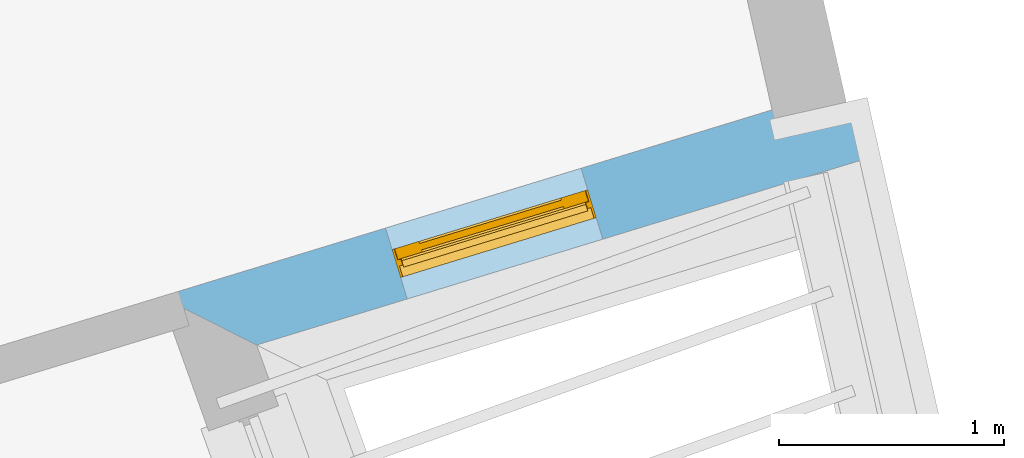
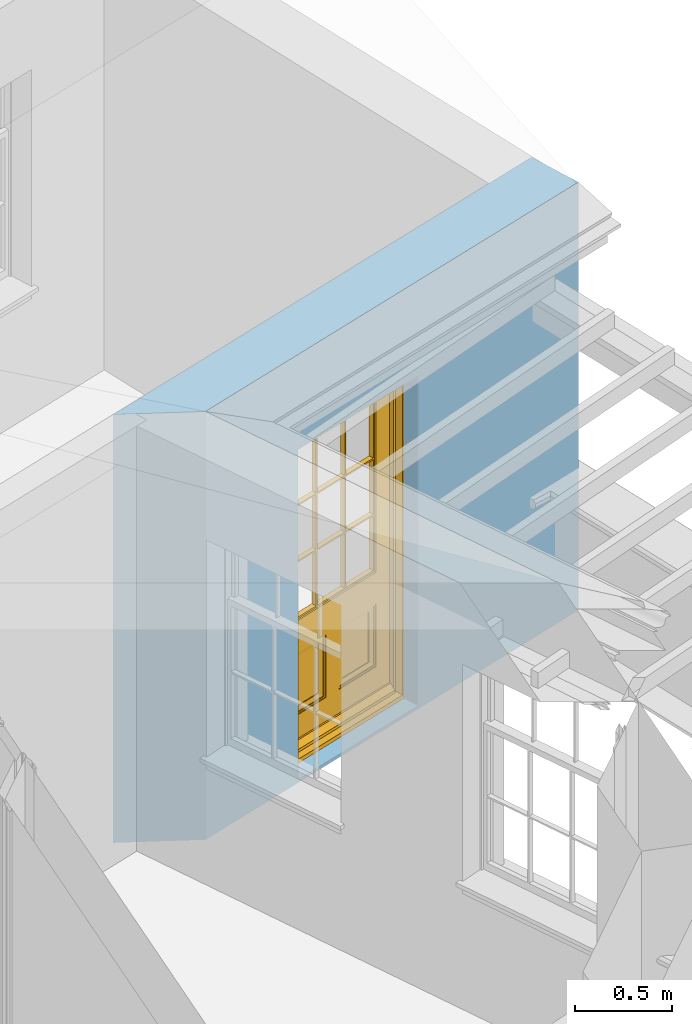
# One storey, part 7 of 10: 1 door, 1 opening, plus 1 element that does not belong to this part.
"""IFC2X3 building model written with IfcOpenShell, lengths in metres."""

from ifc_helpers import new_model, si_unit, frame, origin, place, context, subcontext, project, spatial, polyline, outline, extrude, faceted_brep, material, layer, layer_set, layer_usage, element, fill, save


model = new_model("IFC2X3")

# Units and contexts
model_context = context("Model", 3, world=origin())
body_context = subcontext(model_context, "Body", "Model", "MODEL_VIEW")
ifc_project = project(units=[si_unit("PLANEANGLEUNIT", "RADIAN"), si_unit("MASSUNIT", "GRAM", prefix="KILO"), si_unit("FORCEUNIT", "NEWTON", prefix="KILO"), si_unit("LENGTHUNIT", "METRE")], contexts=[model_context])

# Site, building, storey
site_placement = place(None, origin())
site = spatial("IfcSite", under=ifc_project, at=site_placement, CompositionType="ELEMENT")
building_placement = place(None, origin())
building = spatial("IfcBuilding", under=site, at=building_placement, Name="Building plot-9", CompositionType="ELEMENT")
storey_placement = place(None, frame((0.0, 0.0, 4.3)))
storey = spatial("IfcBuildingStorey", under=building, at=storey_placement, Name="Floor 1", CompositionType="ELEMENT", Elevation=4.3)

# Wall, opening, door
ifc_material = material(Name="Masonry")
ifc_layer = layer(ifc_material, 0.33, ventilated=False)
ifc_layer_set = layer_set([ifc_layer], Name="My Wall")
ifc_layer_usage = layer_usage(ifc_layer_set, "AXIS2", "NEGATIVE", 0.08)
wall_placement = place(storey_placement, origin())
wall = element("IfcWallStandardCase", 1, at=wall_placement, inside=storey, material=ifc_layer_usage, Name="exterior", context=body_context, shape_type="SweptSolid", body=[
    extrude(outline(polyline([(38.174894424001, 19.9322512434462), (38.6024618598675, 19.7178854834714), (41.3015513002929, 20.5430150145373), (41.2050755797842, 20.8585977063192), (38.174894424001, 19.9322512434462)])), origin(), (0.0, 0.0, 1.0), 2.7),
])
opening_placement = place(storey_placement, frame((0.0, 0.0, 0.0199999999999996)))
opening = element("IfcOpeningElement", 2, at=opening_placement, cuts=wall, Name="Opening", ObjectType="Opening", context=body_context, shape_type="SweptSolid", body=[
    extrude(outline(polyline([(39.2719325629492, 19.9225471145469), (40.1421757433175, 20.1885862226164), (40.0457000228088, 20.5041689143983), (39.1754568424405, 20.2381298063288), (39.2719325629492, 19.9225471145469)])), origin(), (0.0, 0.0, 1.0), 2.08),
])
door_placement = place(storey_placement, frame((39.1988448958971, 20.1616249113514, 0.0199999999999996), z_axis=(0.0, 0.0, 1.0), x_axis=(0.870243180368334, 0.266039108069496, 0.0)))
door = element("IfcDoor", 3, at=door_placement, inside=storey, Name="bedroom outside door", OverallHeight=2.08, OverallWidth=0.91, context=body_context, shape_type="Brep", held_by="IfcProductRepresentation", body=[
    faceted_brep([(0.545, -0.055, 0.265), (0.745, -0.055, 0.265), (0.745, -0.05, 0.265), (0.545, -0.05, 0.265), (0.745, -0.05, 0.58), (0.545, -0.05, 0.58), (0.545, -0.055, 0.58), (0.515, -0.06, 0.235), (0.775, -0.06, 0.235), (0.745, -0.055, 0.58), (0.515, -0.06, 0.61), (0.515, -0.065, 0.235), (0.775, -0.065, 0.235), (0.775, -0.06, 0.61), (0.515, -0.065, 0.61), (0.785, -0.065, 0.225), (0.505, -0.065, 0.225), (0.775, -0.065, 0.61), (0.505, -0.065, 0.62), (0.785, -0.065, 0.62), (0.505, -0.07, 0.225), (0.785, -0.07, 0.225), (0.505, -0.07, 0.62), (0.785, -0.07, 0.62), (0.883, -0.07, 0.075), (0.898, -0.07, 0.075), (0.405, -0.07, 0.62), (0.405, -0.07, 0.225), (0.027, -0.07, 0.075), (0.785, -0.07, 0.82), (0.125, -0.07, 0.82), (0.405, -0.065, 0.62), (0.405, -0.065, 0.225), (0.898, -0.07, 2.068), (0.027, -0.08, 0.075), (0.883, -0.08, 0.075), (0.125, -0.07, 0.225), (0.012, -0.07, 0.075), (0.785, -0.06, 0.82), (0.125, -0.06, 0.82), (0.125, -0.07, 0.62), (0.125, -0.065, 0.62), (0.395, -0.065, 0.61), (0.395, -0.065, 0.235), (0.125, -0.065, 0.225), (0.785, -0.07, 1.895), (0.027, -0.11, 0.045), (0.883, -0.11, 0.045), (0.558333, -0.06, 0.83), (0.351667, -0.06, 0.83), (0.125, -0.07, 1.895), (0.125, -0.06, 1.895), (0.785, -0.06, 1.895), (0.012, -0.07, 2.068), (0.135, -0.065, 0.61), (0.395, -0.06, 0.61), (0.395, -0.06, 0.235), (0.135, -0.065, 0.235), (0.027, -0.11, 0.027), (0.883, -0.11, 0.027), (0.568333, -0.06, 0.83), (0.558333, -0.03, 0.83), (0.351667, -0.03, 0.83), (0.341667, -0.06, 0.83), (0.135, -0.06, 1.185), (0.135, -0.06, 1.53), (0.775, -0.06, 1.53), (0.775, -0.06, 1.185), (0.135, -0.06, 0.61), (0.365, -0.055, 0.58), (0.365, -0.055, 0.265), (0.135, -0.06, 0.235), (0.568333, -0.06, 1.175), (0.558333, -0.06, 1.175), (0.775, -0.06, 0.83), (0.558333, -0.03, 1.175), (0.785, -0.03, 0.82), (0.125, -0.03, 0.82), (0.351667, -0.03, 1.175), (0.351667, -0.06, 1.175), (0.341667, -0.06, 1.175), (0.135, -0.06, 0.83), (0.135, -0.06, 1.175), (0.135, -0.03, 1.185), (0.135, -0.03, 1.53), (0.135, -0.06, 1.54), (0.351667, -0.06, 1.885), (0.558333, -0.06, 1.885), (0.775, -0.03, 1.53), (0.775, -0.03, 1.185), (0.775, -0.06, 1.175), (0.775, -0.06, 1.54), (0.165, -0.055, 0.58), (0.365, -0.05, 0.58), (0.365, -0.05, 0.265), (0.165, -0.055, 0.265), (0.568333, -0.03, 0.83), (0.568333, -0.03, 1.175), (0.568333, -0.06, 1.185), (0.558333, -0.06, 1.185), (0.775, -0.03, 0.83), (0.785, -0.02, 0.82), (0.125, -0.02, 0.82), (0.341667, -0.03, 0.83), (0.341667, -0.03, 1.175), (0.351667, -0.06, 1.185), (0.341667, -0.06, 1.185), (0.135, -0.03, 0.83), (0.341667, -0.03, 1.185), (0.125, -0.03, 1.895), (0.341667, -0.03, 1.53), (0.341667, -0.06, 1.53), (0.135, -0.06, 1.885), (0.341667, -0.06, 1.54), (0.341667, -0.06, 1.885), (0.558333, -0.03, 1.885), (0.351667, -0.03, 1.885), (0.568333, -0.06, 1.885), (0.785, -0.03, 1.895), (0.568333, -0.03, 1.185), (0.568333, -0.06, 1.53), (0.568333, -0.03, 1.53), (0.568333, -0.06, 1.54), (0.775, -0.06, 1.885), (0.165, -0.05, 0.58), (0.165, -0.05, 0.265), (0.775, -0.03, 1.175), (0.558333, -0.06, 1.53), (0.351667, -0.03, 1.185), (0.558333, -0.03, 1.185), (0.505, -0.02, 0.62), (0.405, -0.02, 0.62), (0.125, -0.02, 1.895), (0.785, -0.02, 1.895), (0.351667, -0.06, 1.53), (0.135, -0.03, 1.175), (0.135, -0.03, 1.54), (0.341667, -0.03, 1.54), (0.135, -0.03, 1.885), (0.351667, -0.06, 1.54), (0.558333, -0.03, 1.54), (0.558333, -0.06, 1.54), (0.351667, -0.03, 1.54), (0.775, -0.03, 1.54), (0.568333, -0.03, 1.54), (0.775, -0.03, 1.885), (0.558333, -0.03, 1.53), (0.405, -0.02, 0.225), (0.505, -0.02, 0.225), (0.125, -0.02, 0.62), (0.785, -0.02, 0.62), (0.012, -0.02, 2.068), (0.898, -0.02, 2.068), (0.351667, -0.03, 1.53), (0.341667, -0.03, 1.885), (0.568333, -0.03, 1.885), (0.405, -0.025, 0.225), (0.405, -0.025, 0.62), (0.505, -0.025, 0.62), (0.505, -0.025, 0.225), (0.898, -0.02, 0.027), (0.012, -0.02, 0.027), (0.125, -0.025, 0.62), (0.785, -0.025, 0.62), (0.395, -0.025, 0.235), (0.395, -0.025, 0.61), (0.125, -0.02, 0.225), (0.125, -0.025, 0.225), (0.515, -0.025, 0.61), (0.515, -0.025, 0.235), (0.785, -0.02, 0.225), (0.785, -0.025, 0.225), (0.135, -0.025, 0.61), (0.775, -0.025, 0.61), (0.135, -0.025, 0.235), (0.395, -0.03, 0.235), (0.395, -0.03, 0.61), (0.515, -0.03, 0.61), (0.515, -0.03, 0.235), (0.775, -0.025, 0.235), (0.135, -0.03, 0.61), (0.775, -0.03, 0.61), (0.135, -0.03, 0.235), (0.365, -0.035, 0.265), (0.365, -0.035, 0.58), (0.545, -0.035, 0.58), (0.545, -0.035, 0.265), (0.775, -0.03, 0.235), (0.165, -0.035, 0.58), (0.745, -0.035, 0.58), (0.165, -0.035, 0.265), (0.365, -0.04, 0.58), (0.365, -0.04, 0.265), (0.545, -0.04, 0.58), (0.545, -0.04, 0.265), (0.745, -0.035, 0.265), (0.165, -0.04, 0.58), (0.745, -0.04, 0.58), (0.165, -0.04, 0.265), (0.745, -0.04, 0.265), (0.885, -0.072, 0.025), (0.025, -0.072, 0.025), (0.025, -0.1, 0.025), (0.885, -0.1, 0.025), (0.9, -0.02, 0.025), (0.01, -0.02, 0.025), (0.9, -0.072, 0.025), (0.91, -0.02, 0.0), (0.0, -0.02, 0.0), (0.01, -0.072, 0.025), (0.9, -0.072, 2.07), (0.9, -0.02, 2.07), (0.885, -0.072, 2.055), (0.91, -0.02, 2.08), (0.01, -0.02, 2.07), (0.0, -0.02, 2.08), (0.01, -0.072, 2.07), (0.025, -0.072, 2.055), (0.0, -0.15, 2.08), (0.91, -0.15, 2.08), (0.01, -0.15, 2.07), (0.9, -0.15, 2.07), (0.01, -0.1, 2.07), (0.9, -0.1, 2.07), (0.0, -0.15, 0.0), (0.91, -0.15, 0.0), (0.01, -0.15, 0.025), (0.9, -0.15, 0.025), (0.01, -0.1, 0.025), (0.025, -0.1, 2.055), (0.9, -0.1, 0.025), (0.885, -0.1, 2.055), (0.898, -0.07, 0.027), (0.012, -0.07, 0.027), (0.883, -0.07, 0.027), (0.027, -0.07, 0.027)], [[[0, 1, 2, 3]], [[2, 4, 5, 3]], [[0, 3, 5, 6]], [[1, 0, 7, 8]], [[9, 4, 2, 1]], [[9, 6, 5, 4]], [[0, 6, 10, 7]], [[8, 7, 11, 12]], [[8, 13, 9, 1]], [[13, 10, 6, 9]], [[7, 10, 14, 11]], [[15, 12, 11, 16]], [[12, 17, 13, 8]], [[17, 14, 10, 13]], [[18, 16, 11, 14]], [[15, 19, 17, 12]], [[15, 16, 20, 21]], [[14, 17, 19, 18]], [[16, 18, 22, 20]], [[21, 23, 19, 15]], [[24, 25, 21, 20]], [[23, 22, 18, 19]], [[20, 22, 26, 27]], [[23, 21, 25]], [[28, 24, 20, 27]], [[22, 23, 29]], [[29, 30, 26, 22]], [[27, 26, 31, 32]], [[23, 25, 33, 29]], [[34, 35, 24, 28]], [[28, 27, 36, 37]], [[38, 39, 30, 29]], [[26, 30, 40]], [[26, 40, 41, 31]], [[42, 43, 32, 31]], [[32, 44, 36, 27]], [[33, 45, 29]], [[46, 47, 35, 34]], [[36, 40, 37]], [[39, 38, 48, 49]], [[50, 30, 39, 51]], [[29, 45, 52, 38]], [[53, 37, 40, 30]], [[44, 41, 40, 36]], [[31, 41, 54, 42]], [[43, 42, 55, 56]], [[57, 44, 32, 43]], [[50, 45, 33, 53]], [[47, 46, 58, 59]], [[60, 48, 38]], [[49, 48, 61, 62]], [[49, 63, 39]], [[50, 53, 30]], [[51, 39, 64, 65]], [[45, 50, 51, 52]], [[66, 67, 38, 52]], [[57, 54, 41, 44]], [[42, 54, 68, 55]], [[56, 55, 69, 70]], [[56, 71, 57, 43]], [[60, 72, 73, 48]], [[60, 38, 74]], [[48, 73, 75, 61]], [[76, 77, 62, 61]], [[62, 78, 79, 49]], [[49, 79, 80, 63]], [[63, 81, 39]], [[82, 64, 39]], [[65, 64, 83, 84]], [[85, 51, 65]], [[52, 51, 86, 87]], [[88, 89, 67, 66]], [[90, 38, 67]], [[91, 66, 52]], [[71, 68, 54, 57]], [[55, 68, 92, 69]], [[69, 93, 94, 70]], [[70, 95, 71, 56]], [[96, 97, 72, 60]], [[73, 72, 98, 99]], [[74, 38, 90]], [[100, 96, 60, 74]], [[75, 73, 79, 78]], [[61, 75, 97, 96]], [[101, 102, 77, 76]], [[77, 103, 62]], [[96, 76, 61]], [[103, 104, 78, 62]], [[80, 79, 105, 106]], [[63, 80, 104, 103]], [[81, 63, 103, 107]], [[81, 82, 39]], [[106, 64, 82, 80]], [[106, 108, 83, 64]], [[84, 83, 77, 109]], [[110, 111, 65, 84]], [[112, 51, 85]], [[113, 85, 65, 111]], [[114, 86, 51]], [[115, 87, 86, 116]], [[117, 52, 87]], [[118, 76, 89, 88]], [[119, 98, 67, 89]], [[120, 121, 88, 66]], [[67, 98, 72, 90]], [[91, 122, 120, 66]], [[91, 52, 123]], [[95, 92, 68, 71]], [[69, 92, 124, 93]], [[94, 93, 124, 125]], [[94, 125, 95, 70]], [[72, 97, 126, 90]], [[127, 99, 98, 120]], [[99, 105, 79, 73]], [[74, 90, 126, 100]], [[96, 100, 76]], [[128, 129, 75, 78]], [[97, 75, 129, 119]], [[130, 131, 102, 101]], [[109, 77, 102, 132]], [[133, 101, 76, 118]], [[77, 107, 103]], [[78, 104, 108, 128]], [[111, 106, 105, 134]], [[104, 80, 82, 135]], [[107, 135, 82, 81]], [[110, 108, 106, 111]], [[104, 135, 83, 108]], [[83, 135, 77]], [[136, 84, 109]], [[110, 84, 136, 137]], [[114, 51, 112]], [[85, 136, 138, 112]], [[113, 137, 136, 85]], [[111, 134, 139, 113]], [[86, 114, 113, 139]], [[140, 141, 87, 115]], [[139, 142, 116, 86]], [[109, 118, 115, 116]], [[117, 123, 52]], [[117, 87, 141, 122]], [[126, 89, 76]], [[143, 118, 88]], [[120, 98, 119, 121]], [[119, 89, 126, 97]], [[144, 143, 88, 121]], [[144, 122, 91, 143]], [[127, 120, 122, 141]], [[143, 91, 123, 145]], [[124, 92, 95, 125]], [[146, 129, 99, 127]], [[99, 129, 128, 105]], [[100, 126, 76]], [[121, 119, 129, 146]], [[147, 131, 130, 148]], [[131, 149, 102]], [[130, 101, 150]], [[102, 151, 132]], [[118, 109, 132, 133]], [[101, 133, 152]], [[107, 77, 135]], [[153, 128, 108, 110]], [[134, 105, 128, 153]], [[109, 138, 136]], [[153, 110, 137, 142]], [[154, 114, 112, 138]], [[137, 113, 114, 154]], [[141, 139, 134, 127]], [[141, 140, 142, 139]], [[144, 140, 115, 155]], [[142, 137, 154, 116]], [[155, 115, 118]], [[116, 154, 109]], [[117, 155, 145, 123]], [[122, 144, 155, 117]], [[143, 145, 118]], [[121, 146, 140, 144]], [[146, 127, 134, 153]], [[156, 157, 131, 147]], [[148, 130, 158, 159]], [[148, 160, 161, 147]], [[157, 162, 149, 131]], [[161, 151, 102, 149]], [[101, 152, 160, 150]], [[163, 158, 130, 150]], [[151, 152, 133, 132]], [[154, 138, 109]], [[142, 140, 146, 153]], [[145, 155, 118]], [[157, 156, 164, 165]], [[147, 166, 167, 156]], [[168, 169, 159, 158]], [[170, 148, 159, 171]], [[148, 170, 160]], [[166, 147, 161]], [[172, 162, 157, 165]], [[166, 149, 162, 167]], [[166, 161, 149]], [[150, 160, 170]], [[163, 173, 168, 158]], [[171, 163, 150, 170]], [[174, 164, 156, 167]], [[175, 176, 165, 164]], [[169, 168, 177, 178]], [[171, 159, 169, 179]], [[167, 162, 172, 174]], [[176, 180, 172, 165]], [[179, 173, 163, 171]], [[181, 177, 168, 173]], [[164, 174, 182, 175]], [[183, 184, 176, 175]], [[178, 177, 185, 186]], [[179, 169, 178, 187]], [[174, 172, 180, 182]], [[184, 188, 180, 176]], [[187, 181, 173, 179]], [[189, 185, 177, 181]], [[175, 182, 190, 183]], [[191, 184, 183, 192]], [[185, 193, 194, 186]], [[187, 178, 186, 195]], [[182, 180, 188, 190]], [[191, 196, 188, 184]], [[195, 189, 181, 187]], [[197, 193, 185, 189]], [[183, 190, 198, 192]], [[198, 196, 191, 192]], [[194, 193, 197, 199]], [[195, 186, 194, 199]], [[188, 196, 198, 190]], [[197, 189, 195, 199]], [[200, 201, 202, 203]], [[201, 200, 204, 205]], [[206, 204, 200]], [[204, 207, 208, 205]], [[209, 201, 205]], [[210, 211, 204, 206]], [[206, 200, 212, 210]], [[211, 213, 207, 204]], [[214, 205, 208, 215]], [[216, 217, 201, 209]], [[205, 214, 216, 209]], [[216, 214, 211, 210]], [[210, 212, 217, 216]], [[214, 215, 213, 211]], [[218, 219, 213, 215]], [[219, 218, 220, 221]], [[221, 220, 222, 223]], [[215, 208, 224, 218]], [[225, 224, 208, 207]], [[224, 226, 220, 218]], [[224, 225, 227, 226]], [[219, 225, 207, 213]], [[228, 222, 220, 226]], [[219, 221, 227, 225]], [[226, 227, 203, 202]], [[202, 229, 222, 228]], [[228, 226, 202]], [[227, 221, 223, 230]], [[230, 203, 227]], [[217, 229, 202, 201]], [[231, 223, 222, 229]], [[230, 223, 231, 203]], [[231, 229, 217, 212]], [[212, 200, 203, 231]], [[33, 152, 151, 53]], [[25, 160, 152, 33]], [[161, 37, 53, 151]], [[232, 160, 25]], [[161, 233, 37]], [[160, 232, 234]], [[24, 234, 232, 25]], [[233, 161, 235]], [[37, 233, 235, 28]], [[161, 160, 234, 235]], [[35, 47, 234, 24]], [[28, 235, 46, 34]], [[58, 235, 234, 59]], [[59, 234, 47]], [[58, 46, 235]]]),
])
fill(opening, door)

save(model, "model.ifc")
